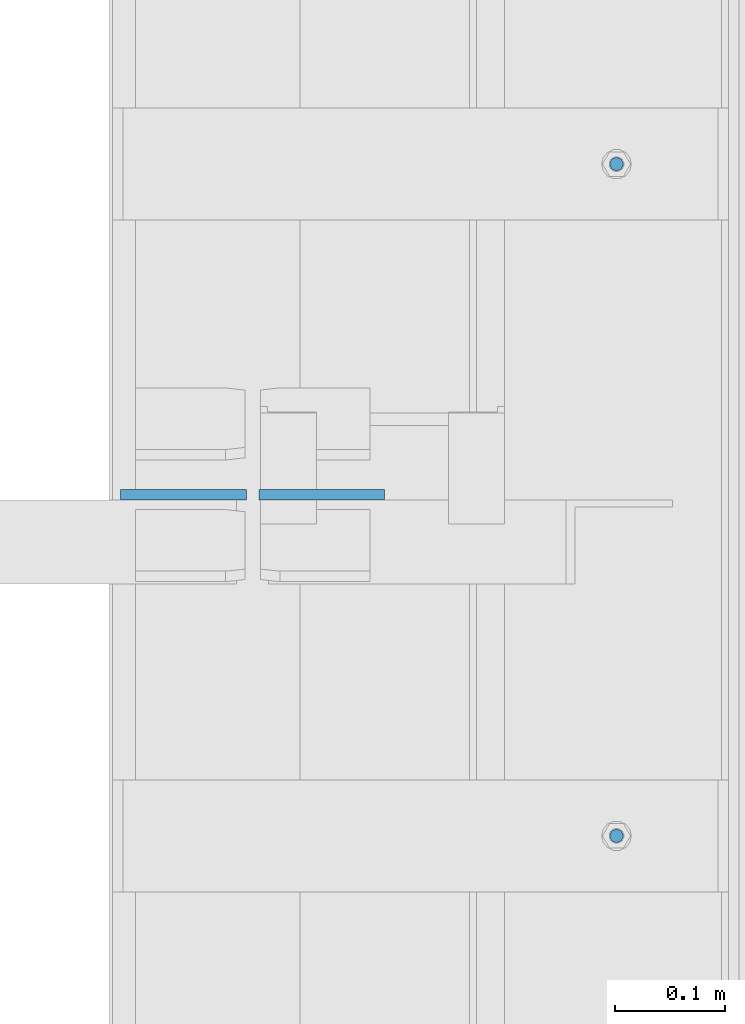
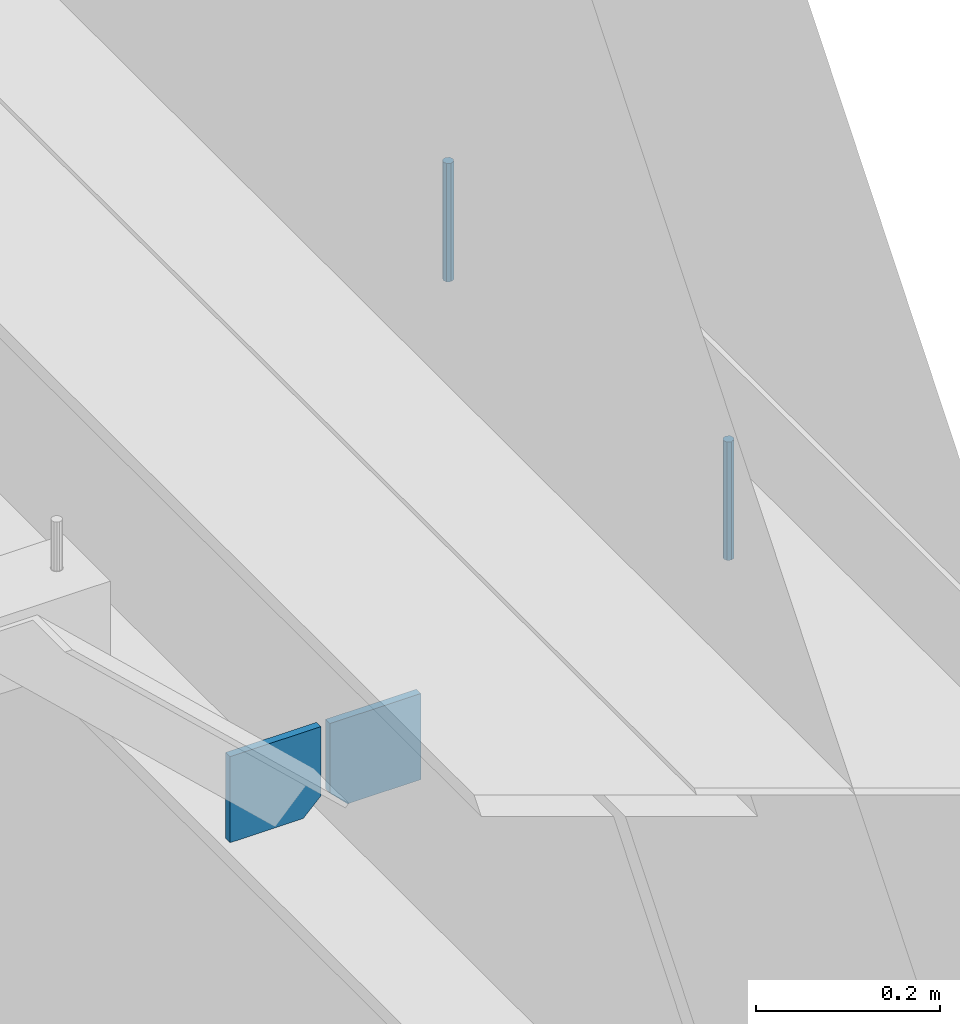
# One storey, part 460 of 1179: 4 columns, 1 element without a shape of its own.
"""IFC2X3 building model written with IfcOpenShell, lengths in millimetres."""

import ifcopenshell
import ifcopenshell.guid

model = None  # the IFC model being written
_history = None  # IfcOwnerHistory: only IFC2X3 demands one
_inside = {}  # id of a spatial element -> (the spatial element, [elements in it])
_under = {}  # id of a project, library or spatial element -> (it, [spatial elements below it])
_declared = {}  # id of a project -> (the project, [libraries it declares])
_typed = {}  # id of a type object -> (the type object, [elements of that type])
_made_of = {}  # id of a material, layer set ... -> (it, [elements and type objects made of it])


def new_model(schema):
    """Start an empty IFC model of exactly this schema.

    Asked for "IFC4X3", IfcOpenShell would pick the latest addendum, in which some entities
    have other attributes; the version numbers below select the first issue.
    IFC2X3 requires an IfcOwnerHistory on every rooted entity: one is made here for all.
    """
    global model, _history
    if schema == "IFC4X3":
        model = ifcopenshell.file(schema_version=(4, 3, 0, 0))
    else:
        model = ifcopenshell.file(schema=schema)
    _inside.clear()
    _under.clear()
    _declared.clear()
    _typed.clear()
    _made_of.clear()
    _history = None
    if model.schema == "IFC2X3":
        org = make("IfcOrganization", Name="unknown")
        user = make(
            "IfcPersonAndOrganization",
            ThePerson=make("IfcPerson", FamilyName="unknown"),
            TheOrganization=org,
        )
        app = make(
            "IfcApplication",
            ApplicationDeveloper=org,
            Version="unknown",
            ApplicationFullName="unknown",
            ApplicationIdentifier="unknown",
        )
        _history = make(
            "IfcOwnerHistory",
            OwningUser=user,
            OwningApplication=app,
            ChangeAction="ADDED",
            CreationDate=0,
        )
    return model


def make(cls, **values):
    """One entity of the class cls with the attributes given. An attribute that is None is left unset."""
    return model.create_entity(
        cls, **{name: value for name, value in values.items() if value is not None}
    )


def rooted(cls, **values):
    """An entity with a GlobalId (a new one), such as an element, a storey or a relation."""
    return make(cls, GlobalId=ifcopenshell.guid.new(), OwnerHistory=_history, **values)


def si_unit(unit_type, name, prefix=None):
    """IfcSIUnit, for example si_unit("LENGTHUNIT", "METRE", prefix="MILLI")."""
    return make("IfcSIUnit", UnitType=unit_type, Prefix=prefix, Name=name)


def assignment(units):
    """IfcUnitAssignment: the units of a project."""
    return None if units is None else make("IfcUnitAssignment", Units=units)


def point(xyz):
    """IfcCartesianPoint."""
    return None if xyz is None else make("IfcCartesianPoint", Coordinates=xyz)


def direction(xyz):
    """IfcDirection."""
    return None if xyz is None else make("IfcDirection", DirectionRatios=xyz)


def frame(location, z_axis=None, x_axis=None):
    """IfcAxis2Placement3D, a coordinate frame: its origin and axes. An axis left out is left unset."""
    return make(
        "IfcAxis2Placement3D",
        Location=point(location),
        Axis=direction(z_axis),
        RefDirection=direction(x_axis),
    )


def origin_with_axes():
    """The frame at (0, 0, 0) with the z axis (0, 0, 1) and the x axis (1, 0, 0) written out."""
    return frame((0.0, 0.0, 0.0), z_axis=(0.0, 0.0, 1.0), x_axis=(1.0, 0.0, 0.0))


def place(relative_to, where):
    """IfcLocalPlacement: puts the frame where relative to a parent placement (None: the world)."""
    return make(
        "IfcLocalPlacement", PlacementRelTo=relative_to, RelativePlacement=where
    )


def context(
    kind, dimensions, precision=None, world=None, true_north=None, identifier=None
):
    """IfcGeometricRepresentationContext, for example the 3D "Model" context."""
    return make(
        "IfcGeometricRepresentationContext",
        ContextIdentifier=identifier,
        ContextType=kind,
        CoordinateSpaceDimension=dimensions,
        Precision=precision,
        WorldCoordinateSystem=world,
        TrueNorth=true_north,
    )


def subcontext(parent, identifier, kind, view, scale=None):
    """IfcGeometricRepresentationSubContext, for example "Body" below "Model"."""
    return make(
        "IfcGeometricRepresentationSubContext",
        ContextIdentifier=identifier,
        ContextType=kind,
        ParentContext=parent,
        TargetScale=scale,
        TargetView=view,
    )


def project(units=None, contexts=None):
    """IfcProject with its units and contexts."""
    return rooted(
        "IfcProject",
        Name="project",
        RepresentationContexts=contexts,
        UnitsInContext=assignment(units),
    )


def spatial(cls, under=None, at=None, **own):
    """A site, building, storey or space (cls), placed at a placement, below another one or the project."""
    s = rooted(cls, ObjectPlacement=at, **own)
    if under is not None:
        _under.setdefault(under.id(), (under, []))[1].append(s)
    return s


def faces_of(points, faces, orient=None, outer=None):
    """IfcFace entities. A face is a list of loops; a loop is a list of indices into points, from 0.

    orient and outer hold one flag for each loop. By default every Orientation is true, the
    first loop of a face is its IfcFaceOuterBound and the others are IfcFaceBound.
    """
    made = []
    for i, loops in enumerate(faces):
        bounds = []
        for j, loop in enumerate(loops):
            is_outer = j == 0 if outer is None else outer[i][j]
            bounds.append(
                make(
                    "IfcFaceOuterBound" if is_outer else "IfcFaceBound",
                    Bound=make("IfcPolyLoop", Polygon=[points[k] for k in loop]),
                    Orientation=True if orient is None else orient[i][j],
                )
            )
        made.append(make("IfcFace", Bounds=bounds))
    return made


def faceted_brep(points, faces, orient=None, outer=None, voids=None):
    """IfcFacetedBrep: a solid bounded by flat faces; with voids (closed shells), ...WithVoids."""
    shared = [point(p) for p in points]
    hull = make("IfcClosedShell", CfsFaces=faces_of(shared, faces, orient, outer))
    if voids is None:
        return make("IfcFacetedBrep", Outer=hull)
    return make(
        "IfcFacetedBrepWithVoids",
        Outer=hull,
        Voids=[
            make(cls, CfsFaces=faces_of(shared, fs, o, b)) for cls, fs, o, b in voids
        ],
    )


def shape(context_of_items, identifier, shape_type, items):
    """IfcShapeRepresentation: the items that make up one representation, for example the "Body"."""
    return make(
        "IfcShapeRepresentation",
        ContextOfItems=context_of_items,
        RepresentationIdentifier=identifier,
        RepresentationType=shape_type,
        Items=items,
    )


def material(Name=None, Category=None):
    """IfcMaterial."""
    return make("IfcMaterial", Name=Name, Category=Category)


def made_of(thing, what):
    """Note that an element or type object is made of a material, layer set ...; save() writes the relation."""
    if what is not None:
        _made_of.setdefault(what.id(), (what, []))[1].append(thing)
    return thing


def type_object(cls, material=None, **own):
    """A type object (cls), such as IfcWallType, which elements share."""
    return made_of(rooted(cls, **own), material)


def element(
    cls,
    number,
    at=None,
    inside=None,
    cuts=None,
    type_object=None,
    material=None,
    context=None,
    identifier="Body",
    shape_type=None,
    held_by="IfcProductDefinitionShape",
    body=None,
    shapes=None,
    **own,
):
    """One element of the class cls, such as IfcWall. Its Tag is "e" and its number.

    at: its placement. inside: the storey or other place that contains it. cuts: it is an
    opening in that element (IfcRelVoidsElement). A single representation is given by context,
    identifier, shape_type and body (its items); several are given by shapes. held_by: the class
    of the entity that holds the representations. save() writes the other relations.
    """
    e = rooted(cls, Tag="e%d" % number, ObjectPlacement=at, **own)
    if body is not None:
        shapes = [shape(context, identifier, shape_type, body)]
    if shapes is not None:
        e.Representation = make(held_by, Representations=shapes)
    if inside is not None:
        _inside.setdefault(inside.id(), (inside, []))[1].append(e)
    if cuts is not None:
        rooted(
            "IfcRelVoidsElement", RelatingBuildingElement=cuts, RelatedOpeningElement=e
        )
    if type_object is not None:
        _typed.setdefault(type_object.id(), (type_object, []))[1].append(e)
    return made_of(e, material)


def aggregate(whole, parts):
    """IfcRelAggregates: a whole, such as a stair, and the parts it consists of."""
    return rooted("IfcRelAggregates", RelatingObject=whole, RelatedObjects=parts)


def save(model, path):
    """Write the relations noted so far, then the file.

    IfcRelAggregates (storeys below a building ...), IfcRelContainedInSpatialStructure (elements
    in a storey), IfcRelDefinesByType, IfcRelAssociatesMaterial and IfcRelDeclares: one each for
    every whole, place, type object, material and project.
    """
    for whole, parts in _under.values():
        aggregate(whole, parts)
    for where, things in _inside.values():
        rooted(
            "IfcRelContainedInSpatialStructure",
            RelatedElements=things,
            RelatingStructure=where,
        )
    for kind, things in _typed.values():
        rooted("IfcRelDefinesByType", RelatedObjects=things, RelatingType=kind)
    for what, things in _made_of.values():
        rooted("IfcRelAssociatesMaterial", RelatedObjects=things, RelatingMaterial=what)
    for by, libraries in _declared.values():
        rooted("IfcRelDeclares", RelatingContext=by, RelatedDefinitions=libraries)
    model.write(path)


model = new_model("IFC2X3")

# Units and contexts
model_context = context("Model", 3, precision=1e-05, world=origin_with_axes())
body_context = subcontext(model_context, "Body", "Model", "MODEL_VIEW")
ifc_project = project(units=[si_unit("LENGTHUNIT", "METRE", prefix="MILLI"), si_unit("AREAUNIT", "SQUARE_METRE"), si_unit("VOLUMEUNIT", "CUBIC_METRE"), si_unit("MASSUNIT", "GRAM", prefix="KILO"), si_unit("TIMEUNIT", "SECOND"), si_unit("PLANEANGLEUNIT", "RADIAN"), si_unit("SOLIDANGLEUNIT", "STERADIAN"), si_unit("THERMODYNAMICTEMPERATUREUNIT", "DEGREE_CELSIUS"), si_unit("LUMINOUSINTENSITYUNIT", "LUMEN")], contexts=[model_context])

# Site, building, storey
site_placement = place(None, origin_with_axes())
site = spatial("IfcSite", under=ifc_project, at=site_placement, CompositionType="ELEMENT")
building_placement = place(site_placement, origin_with_axes())
building = spatial("IfcBuilding", under=site, at=building_placement, Name="Undefined", CompositionType="ELEMENT")
storey_placement = place(building_placement, origin_with_axes())
storey = spatial("IfcBuildingStorey", under=building, at=storey_placement, Name="Undefined", CompositionType="ELEMENT", Elevation=0.0)

# Assembly, columns
assembly_placement = place(storey_placement, origin_with_axes())
assembly = element("IfcElementAssembly", 1, at=assembly_placement, inside=storey, Name="BEAM", AssemblyPlace="NOTDEFINED", PredefinedType="RIGID_FRAME")
ifc_material_1 = material(Name="STEEL/A36")
column_type_1 = type_object("IfcColumnType", PredefinedType="NOTDEFINED")
column_1_placement = place(assembly_placement, frame((24245.09375, 24058.5625, 3702.05), z_axis=(1.0, 0.0, 0.0), x_axis=(0.0, 0.0, 1.0)))
column_1 = element("IfcColumn", 2, at=column_1_placement, type_object=column_type_1, material=ifc_material_1, Name="PLATE", context=body_context, shape_type="Brep", body=[
    faceted_brep([(22.2250000000004, 4.76250000000073, 57.1500000000015), (0.0, 4.76250000000073, 34.9249999999993), (0.0, -4.76250000000073, 34.9249999999993), (22.2250000000004, -4.76250000000073, 57.1500000000015), (114.300000000001, 4.76250000000073, 57.1500000000015), (114.300000000001, 4.76250000000073, -57.1500000000015), (0.0, 4.76250000000073, -57.1500000000015), (114.300000000001, -4.76250000000073, 57.1500000000015), (0.0, -4.76250000000073, -57.1500000000015), (114.300000000001, -4.76250000000073, -57.1500000000015)], [[[0, 1, 2, 3]], [[4, 5, 6, 1, 0]], [[7, 4, 0, 3]], [[8, 9, 7, 3, 2]], [[8, 6, 5, 9]], [[7, 9, 5, 4]], [[6, 8, 2, 1]]]),
])
column_2_placement = place(assembly_placement, frame((24370.50625, 24058.5625, 3702.05), z_axis=(-1.0, 0.0, 0.0), x_axis=(0.0, 0.0, 1.0)))
column_2 = element("IfcColumn", 3, at=column_2_placement, type_object=column_type_1, material=ifc_material_1, Name="PLATE", context=body_context, shape_type="Brep", body=[
    faceted_brep([(22.2250000000004, 4.76250000000073, 57.1500000000015), (0.0, 4.76250000000073, 34.9249999999993), (0.0, -4.76250000000073, 34.9249999999993), (22.2250000000004, -4.76250000000073, 57.1500000000015), (114.300000000001, 4.76250000000073, 57.1500000000015), (114.300000000001, 4.76250000000073, -57.1500000000015), (0.0, 4.76250000000073, -57.1500000000015), (114.300000000001, -4.76250000000073, 57.1500000000015), (0.0, -4.76250000000073, -57.1500000000015), (114.300000000001, -4.76250000000073, -57.1500000000015)], [[[0, 1, 2, 3]], [[4, 5, 6, 1, 0]], [[7, 4, 0, 3]], [[8, 9, 7, 3, 2]], [[8, 6, 5, 9]], [[7, 9, 5, 4]], [[6, 8, 2, 1]]]),
])
ifc_material_2 = material(Name="STEEL/A307")
column_type_2 = type_object("IfcColumnType", PredefinedType="NOTDEFINED")
column_3_placement = place(assembly_placement, frame((24638.0, 24358.6, 4108.45), z_axis=(0.0, 1.0, 0.0), x_axis=(0.0, 0.0, 1.0)))
column_3 = element("IfcColumn", 4, at=column_3_placement, type_object=column_type_2, material=ifc_material_2, Name="THREADED ROD", context=body_context, shape_type="Brep", body=[
    faceted_brep([(0.0, -6.34999999999854, 0.0), (0.0, -4.49012806053361, -4.49012806053452), (157.162499999999, -4.49012806053361, -4.49012806053361), (157.162499999999, -6.34999999999854, 0.0), (0.0, 0.0, -6.34999999999991), (157.162499999999, 0.0, -6.34999999999854), (0.0, 4.49012806053361, -4.49012806053452), (157.162499999999, 4.49012806053361, -4.49012806053361), (0.0, 6.34999999999854, 0.0), (157.162499999999, 6.34999999999854, 0.0), (0.0, 4.49012806053361, 4.49012806053452), (157.162499999999, 4.49012806053361, 4.49012806053361), (0.0, 0.0, 6.34999999999991), (157.162499999999, 0.0, 6.34999999999854), (0.0, -4.49012806053361, 4.49012806053452), (157.162499999999, -4.49012806053361, 4.49012806053361)], [[[0, 1, 2, 3]], [[1, 4, 5, 2]], [[4, 6, 7, 5]], [[6, 8, 9, 7]], [[8, 10, 11, 9]], [[10, 12, 13, 11]], [[12, 14, 15, 13]], [[14, 0, 3, 15]], [[5, 7, 9, 11, 13, 15, 3, 2]], [[14, 12, 10, 8, 6, 4, 1, 0]]]),
])
column_4_placement = place(assembly_placement, frame((24638.0, 23749.0, 4108.45), z_axis=(0.0, 1.0, 0.0), x_axis=(0.0, 0.0, 1.0)))
column_4 = element("IfcColumn", 5, at=column_4_placement, type_object=column_type_2, material=ifc_material_2, Name="THREADED ROD", context=body_context, shape_type="Brep", body=[
    faceted_brep([(0.0, -6.34999999999854, 0.0), (0.0, -4.49012806053361, -4.49012806053452), (157.162499999999, -4.49012806053361, -4.49012806053361), (157.162499999999, -6.34999999999854, 0.0), (0.0, 0.0, -6.34999999999991), (157.162499999999, 0.0, -6.34999999999854), (0.0, 4.49012806053361, -4.49012806053452), (157.162499999999, 4.49012806053361, -4.49012806053361), (0.0, 6.34999999999854, 0.0), (157.162499999999, 6.34999999999854, 0.0), (0.0, 4.49012806053361, 4.49012806053452), (157.162499999999, 4.49012806053361, 4.49012806053361), (0.0, 0.0, 6.34999999999991), (157.162499999999, 0.0, 6.34999999999854), (0.0, -4.49012806053361, 4.49012806053452), (157.162499999999, -4.49012806053361, 4.49012806053361)], [[[0, 1, 2, 3]], [[1, 4, 5, 2]], [[4, 6, 7, 5]], [[6, 8, 9, 7]], [[8, 10, 11, 9]], [[10, 12, 13, 11]], [[12, 14, 15, 13]], [[14, 0, 3, 15]], [[5, 7, 9, 11, 13, 15, 3, 2]], [[14, 12, 10, 8, 6, 4, 1, 0]]]),
])
aggregate(assembly, [column_3, column_4, column_1, column_2])

save(model, "model.ifc")
